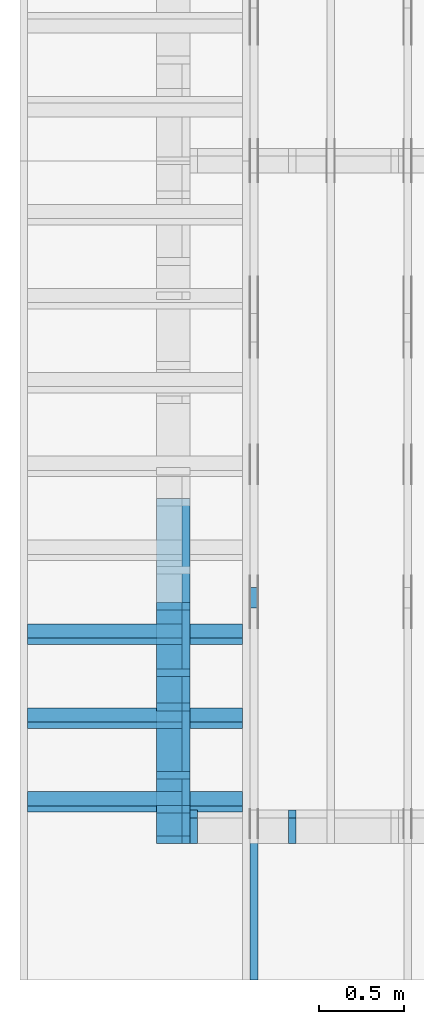
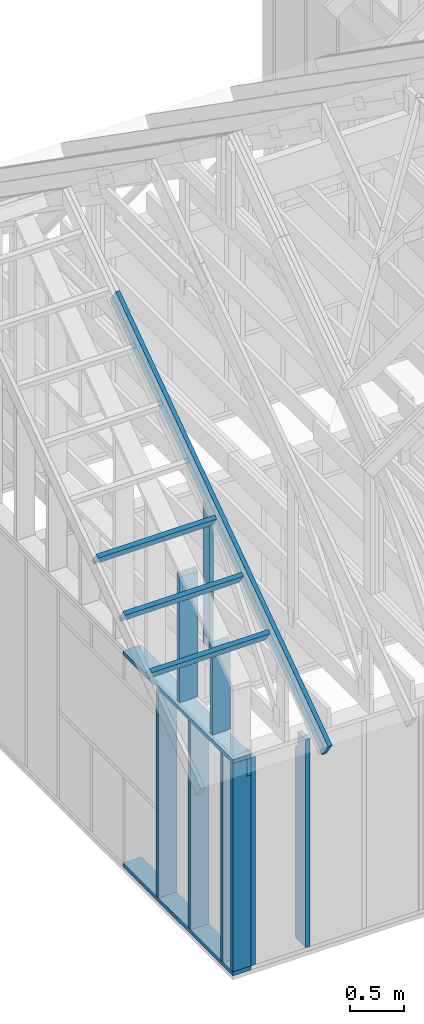
# One storey, part 2 of 70: 16 members, 5 elements without a shape of their own.
"""IFC2X3 building model written with IfcOpenShell, lengths in millimetres."""

from ifc_helpers import new_model, si_unit, frame, origin, origin_with_axes, origin_2d, place, context, project, spatial, faceted_brep, element, aggregate, save


model = new_model("IFC2X3")

# Units and contexts
model_context = context("Model", 3, precision=1e-05, world=origin())
plan_context = context("Plan", 2, precision=1e-05, world=origin_2d())
ifc_project = project(units=[si_unit("LENGTHUNIT", "METRE", prefix="MILLI"), si_unit("AREAUNIT", "SQUARE_METRE"), si_unit("VOLUMEUNIT", "CUBIC_METRE"), si_unit("SOLIDANGLEUNIT", "STERADIAN"), si_unit("PLANEANGLEUNIT", "RADIAN"), si_unit("MASSUNIT", "GRAM"), si_unit("TIMEUNIT", "SECOND"), si_unit("THERMODYNAMICTEMPERATUREUNIT", "DEGREE_CELSIUS"), si_unit("LUMINOUSINTENSITYUNIT", "LUMEN")], contexts=[model_context, plan_context])

# Site, building, storey
site_placement = place(None, origin_with_axes())
site = spatial("IfcSite", under=ifc_project, at=site_placement, CompositionType="ELEMENT")
building_placement = place(site_placement, origin_with_axes())
building = spatial("IfcBuilding", under=site, at=building_placement, Name="Layout 1", CompositionType="ELEMENT")
storey_placement = place(building_placement, origin_with_axes())
storey = spatial("IfcBuildingStorey", under=building, at=storey_placement, Name="Storey 1", CompositionType="ELEMENT", Elevation=0.0)

# Assembly, members
assembly_1_placement = place(storey_placement, frame((304.9999999999989, 8000.000000000001, 1.3776821480501744e-15), z_axis=(-1.0, 1.836909530733566e-16, 6.123031769111886e-17), x_axis=(-1.836909530733566e-16, -1.0, 0.0)))
assembly_1 = element("IfcElementAssembly", 1, at=assembly_1_placement, inside=storey, Name="T2", AssemblyPlace="FACTORY", PredefinedType="TRUSS")
member_1_placement = place(assembly_1_placement, frame((4782.309641268, 3014.9999999994516, -45.00000000000001), z_axis=(0.0, 0.0, 1.0), x_axis=(0.8191520442889916, -0.5735764363510465, 0.0)))
member_1 = element("IfcMember", 2, at=member_1_placement, Name="T9", context=model_context, shape_type="Brep", body=[
    faceted_brep([(4768.153825500908, 195.00000000180353, 45.0), (1.6370904631912708e-10, 195.00000000180353, 45.0), (0.0, 1.8071659724228084e-09, 45.0), (4768.153825500287, 1.8071659724228084e-09, 45.0), (1.6370904631912708e-10, 195.00000000180353, 2.004791383006049e-26), (4768.153825500908, 195.00000000180353, 5.839111470710887e-13), (4768.153825500287, 1.8071659724228084e-09, 5.839111470710126e-13), (0.0, 1.8071659724228084e-09, 0.0), (-1.2523674699591298e-25, 1.8071659724228084e-09, 7.668285805162028e-42), (2.755364295975112e-15, 1.8071659724228084e-09, 45.0), (1.636957134777711e-10, 195.000000001015, 45.0), (1.63692958113475e-10, 195.000000001015, 9.850859431565386e-31), (4768.153825500287, -2.042652045517506e-12, 1.250722336794479e-28), (4768.153825500287, -2.039896681221406e-12, 45.0), (1.0454840658689129e-27, 1.8071687277871045e-09, 45.0), (0.0, 1.8071659724228084e-09, 0.0), (4768.153825500287, 195.00000000180353, -3.8067271842345146e-26), (4768.153825500287, 195.00000000180353, 45.0), (4768.153825500287, 0.0, 45.0), (4768.153825500287, 0.0, 0.0), (1.6370904631912708e-10, 195.000000001015, 0.0), (1.6370904631912708e-10, 195.000000001015, 45.0), (4768.153825500908, 195.00000000180347, 45.0), (4768.153825500908, 195.00000000180347, -4.733165431326071e-30)], [[[0, 1, 2, 3]], [[4, 5, 6, 7]], [[8, 9, 10, 11]], [[12, 13, 14, 15]], [[16, 17, 18, 19]], [[20, 21, 22, 23]]]),
])
member_2_placement = place(assembly_1_placement, frame((6619.999999999389, 220.0, -45.0), z_axis=(0.0, 0.0, 1.0), x_axis=(6.123031769111886e-17, 1.0, 0.0)))
member_2 = element("IfcMember", 3, at=member_2_placement, Name="R1", context=model_context, shape_type="Brep", body=[
    faceted_brep([(1592.2602625068248, 120.0, 45.0), (0.0, 120.0, 45.0), (0.0, 1.4551915228366852e-11, 45.0), (1508.235357921585, 1.4551915228366852e-11, 45.0), (0.0, 120.0, 0.0), (1592.2602625068248, 120.0, 1.949892034404744e-13), (1508.235357921585, 1.4551915228366852e-11, 1.8469946023703405e-13), (0.0, 1.4551915228366852e-11, 0.0), (1.7820367848942657e-27, 1.4551915228366852e-11, -1.0911467847633593e-43), (2.755364296102131e-15, 1.4551915228366852e-11, 45.0), (1.7450640541968876e-14, 120.0, 45.0), (1.4695276245868527e-14, 120.0, -8.997964330932825e-31), (1508.235357921585, -4.605370260698061e-13, 2.81988284147774e-29), (1508.235357921585, -4.577816617737058e-13, 45.0), (2.7425941661909085e-29, 1.4554670592662952e-11, 45.0), (0.0, 1.4551915228366852e-11, 0.0), (1592.260262506825, 120.00000000000011, 1.262177448353619e-29), (1592.260262506825, 120.00000000000011, 45.0), (1508.2353579215853, 0.0, 45.0), (1508.2353579215853, 0.0, 1.262177448353619e-29), (0.0, 120.0, 0.0), (-1.6871183120499046e-31, 120.0, 45.0), (1592.2602625068248, 119.9999999999999, 45.0), (1592.2602625068248, 119.9999999999999, -6.310887241768095e-30)], [[[0, 1, 2, 3]], [[4, 5, 6, 7]], [[8, 9, 10, 11]], [[12, 13, 14, 15]], [[16, 17, 18, 19]], [[20, 21, 22, 23]]]),
])
aggregate(assembly_1, [member_1, member_2])

assembly_2_placement = place(storey_placement, frame((-243.55339059327574, 8000.000000000001, -2470.0), z_axis=(-1.0, 1.836909530733566e-16, 6.123031769111886e-17), x_axis=(-1.836909530733566e-16, -1.0, 0.0)))
assembly_2 = element("IfcElementAssembly", 4, at=assembly_2_placement, inside=storey, Name="VE3", AssemblyPlace="FACTORY", PredefinedType="NOTDEFINED")
member_3_placement = place(assembly_2_placement, frame((5979.999999999998, 2425.0, -195.0), z_axis=(0.0, 0.0, 1.0), x_axis=(1.0, 0.0, 0.0)))
member_3 = element("IfcMember", 5, at=member_3_placement, Name="P11", context=model_context, shape_type="Brep", body=[
    faceted_brep([(2020.0000000000027, 45.0, 195.0), (0.0, 45.0, 195.0), (0.0, 0.0, 195.0), (2020.0000000000027, 0.0, 195.0), (0.0, 45.0, 0.0), (2020.0000000000027, 45.0, 2.4737048347212056e-13), (2020.0000000000027, 0.0, 2.4737048347212056e-13), (0.0, 0.0, 0.0), (0.0, 0.0, 0.0), (1.1939911949768178e-14, -1.462169203776584e-30, 195.0), (1.7450640541968876e-14, 45.0, 195.0), (5.510728592200698e-15, 45.0, -3.3742366240998092e-31), (2020.0000000000027, -3.710557252081808e-13, 2.2719859935605413e-29), (2020.0000000000027, -3.5911581325841264e-13, 195.0), (2.193253805664876e-30, 1.1939911949768178e-14, 195.0), (0.0, 0.0, 0.0), (2020.0000000000027, 45.0, 0.0), (2020.0000000000027, 45.0, 195.0), (2020.0000000000027, 0.0, 195.0), (2020.0000000000027, 0.0, 0.0), (0.0, 45.0, 0.0), (-7.31084601888292e-31, 44.999999999999986, 195.0), (2020.0000000000027, 44.999999999999865, 195.0), (2020.0000000000027, 44.99999999999988, -7.494178599599612e-30)], [[[0, 1, 2, 3]], [[4, 5, 6, 7]], [[8, 9, 10, 11]], [[12, 13, 14, 15]], [[16, 17, 18, 19]], [[20, 21, 22, 23]]]),
])
member_4_placement = place(assembly_2_placement, frame((8000.000000000001, 90.0, -195.0), z_axis=(0.0, 0.0, 1.0), x_axis=(-1.0, 1.2246063538223773e-16, 0.0)))
member_4 = element("IfcMember", 6, at=member_4_placement, Name="P11", context=model_context, shape_type="Brep", body=[
    faceted_brep([(2020.000000000001, 45.00000000000025, 195.0), (0.0, 45.00000000000025, 195.0), (0.0, 0.0, 195.0), (2020.000000000001, 0.0, 195.0), (0.0, 45.00000000000025, 0.0), (2020.000000000001, 45.00000000000025, 2.473704834721203e-13), (2020.000000000001, 0.0, 2.473704834721203e-13), (0.0, 0.0, 0.0), (0.0, 0.0, 0.0), (1.1939911949768178e-14, -1.462169203776584e-30, 195.0), (1.7450640541968876e-14, 45.0, 195.0), (5.510728592200698e-15, 45.0, -3.3742366240998092e-31), (2020.000000000001, -3.7105572520818046e-13, 3.7512157466465997e-29), (2020.000000000001, -3.591158132584123e-13, 195.0), (2.193253805664876e-30, 1.1939911949768178e-14, 195.0), (0.0, 0.0, 0.0), (2020.000000000001, 45.00000000000025, 0.0), (2020.000000000001, 45.00000000000025, 195.0), (2020.000000000001, 2.4158453015843406e-13, 195.0), (2020.000000000001, 2.4158453015843406e-13, 0.0), (0.0, 45.0, 0.0), (1.5777218104420236e-30, 44.999999999999986, 195.0), (2020.000000000001, 45.00000000000031, 195.0), (2020.000000000001, 45.00000000000033, 4.338734978715565e-30)], [[[0, 1, 2, 3]], [[4, 5, 6, 7]], [[8, 9, 10, 11]], [[12, 13, 14, 15]], [[16, 17, 18, 19]], [[20, 21, 22, 23]]]),
])
member_5_placement = place(assembly_2_placement, frame((7955.0, 2425.0, -195.00000000000003), z_axis=(0.0, 0.0, 1.0), x_axis=(-1.836909530733566e-16, -1.0, 0.0)))
member_5 = element("IfcMember", 7, at=member_5_placement, Name="S11", context=model_context, shape_type="Brep", body=[
    faceted_brep([(0.0, 45.0, 45.00000000000003), (195.00000000186265, 45.0, 45.00000000000005), (195.00000000186265, 0.0, 45.00000000000005), (0.0, 0.0, 45.00000000000003), (195.00000000186265, -2.1311460639909362e-46, 2.842170943040401e-14), (195.00000000186265, -3.3742366240998114e-31, 45.00000000000003), (195.00000000186265, 45.0, 45.00000000000003), (195.00000000186265, 45.0, 2.842170943040401e-14), (2.7553642961003504e-15, -3.3742366240998114e-31, 45.00000000000003), (1.193991194976818e-14, -1.4621692037765842e-30, 195.00000000000003), (1.7450640541968876e-14, 45.0, 195.00000000000003), (8.266092888301048e-15, 45.0, 45.00000000000003), (2335.0, -4.2891837542628763e-13, 2.842170943040403e-14), (2335.0, -4.1697846347651946e-13, 195.00000000000003), (2.1932538056648764e-30, 1.193991194976818e-14, 195.00000000000003), (5.061354936149717e-31, 2.7553642961003504e-15, 45.00000000000003), (195.00000000186265, -3.306437155354634e-14, 45.00000000000003), (195.00000000186265, -3.5819735849646686e-14, 2.842170943040401e-14), (-1.6871183120499057e-31, 45.0, 45.00000000000003), (-7.310846018882921e-31, 44.999999999999986, 195.00000000000003), (2335.0, 44.999999999999844, 195.00000000000003), (2335.0, 44.99999999999986, 2.8421709430403998e-14), (195.00000000186265, 44.999999999999986, 2.842170943040401e-14), (195.00000000186265, 44.999999999999986, 45.00000000000003), (2335.0, 45.0, 0.0), (2335.0, 45.0, 195.00000000000003), (2335.0, 0.0, 195.00000000000003), (2335.0, 0.0, 0.0), (2335.0, 45.0, 195.00000000000003), (0.0, 45.0, 195.00000000000003), (0.0, 0.0, 195.00000000000003), (2335.0, 0.0, 195.00000000000003), (195.00000000186265, 45.0, 5.2301533330168465e-14), (2335.0, 45.0, 3.143672930479291e-13), (2335.0, 0.0, 3.143672930479291e-13), (195.00000000186265, 0.0, 5.2301533330168465e-14)], [[[0, 1, 2, 3]], [[4, 5, 6, 7]], [[8, 9, 10, 11]], [[12, 13, 14, 15, 16, 17]], [[18, 19, 20, 21, 22, 23]], [[24, 25, 26, 27]], [[28, 29, 30, 31]], [[32, 33, 34, 35]]]),
])
member_6_placement = place(assembly_2_placement, frame((5980.0, 2230.0, -195.0), z_axis=(0.0, 0.0, 1.0), x_axis=(1.0, 0.0, 0.0)))
member_6 = element("IfcMember", 8, at=member_6_placement, Name="L8", context=model_context, shape_type="Brep", body=[
    faceted_brep([(2020.000000000001, 195.0, 45.0), (0.0, 195.0, 45.0), (0.0, 0.0, 45.0), (2020.000000000001, 0.0, 45.0), (0.0, 195.0, 0.0), (2020.000000000001, 195.0, 2.473704834721203e-13), (2020.000000000001, 0.0, 2.473704834721203e-13), (0.0, 0.0, 0.0), (0.0, 0.0, 0.0), (2.755364296100349e-15, -3.3742366240998092e-31, 45.0), (2.6635188195636705e-14, 195.0, 45.0), (2.3879823899536357e-14, 195.0, -1.462169203776584e-30), (2020.000000000001, -3.7105572520818046e-13, 2.2719859935605393e-29), (2020.000000000001, -3.683003609120801e-13, 45.0), (5.061354936149714e-31, 2.755364296100349e-15, 45.0), (0.0, 0.0, 0.0), (2020.000000000001, 195.0, 0.0), (2020.000000000001, 195.0, 45.0), (2020.000000000001, 0.0, 45.0), (2020.000000000001, 0.0, 0.0), (0.0, 195.0, 0.0), (-1.6871183120499046e-31, 195.0, 45.0), (2020.000000000001, 194.9999999999999, 45.0), (2020.000000000001, 194.9999999999999, -7.888609052210118e-30)], [[[0, 1, 2, 3]], [[4, 5, 6, 7]], [[8, 9, 10, 11]], [[12, 13, 14, 15]], [[16, 17, 18, 19]], [[20, 21, 22, 23]]]),
])
member_7_placement = place(assembly_2_placement, frame((7177.5000000018335, 2425.0, -195.0), z_axis=(0.0, 0.0, 1.0), x_axis=(-1.836909530733566e-16, -1.0, 0.0)))
member_7 = element("IfcMember", 9, at=member_7_placement, Name="S11", context=model_context, shape_type="Brep", body=[
    faceted_brep([(0.0, 44.99999999998545, 45.0), (195.00000000186265, 44.99999999998545, 45.00000000000002), (195.00000000186265, 0.0, 45.00000000000002), (0.0, 0.0, 45.0), (195.00000000186265, 0.0, 0.0), (195.00000000186265, -3.3742366240998092e-31, 45.0), (195.00000000186265, 44.99999999998545, 45.0), (195.00000000186265, 44.99999999998545, 0.0), (2.755364296100349e-15, -3.3742366240998092e-31, 45.0), (1.1939911949768178e-14, -1.462169203776584e-30, 195.0), (1.7450640541967096e-14, 44.99999999998545, 195.00000000000003), (8.266092888299264e-15, 44.99999999998545, 45.0), (2335.0, -4.2891837542628763e-13, 2.626280839091018e-29), (2335.0, -4.1697846347651946e-13, 195.0), (2.193253805664876e-30, 1.1939911949768178e-14, 195.0), (5.061354936149714e-31, 2.755364296100349e-15, 45.0), (195.00000000186265, -3.306437155354634e-14, 45.0), (195.00000000186265, -3.5819735849646686e-14, 2.193253805685826e-30), (-1.6871183120499046e-31, 44.99999999998545, 45.0), (-7.31084601888292e-31, 44.999999999985434, 195.0), (2335.0, 44.99999999998529, 195.0), (2335.0, 44.999999999985306, -8.67746995743113e-30), (195.00000000186265, 44.999999999985434, -7.888609052210118e-31), (195.00000000186265, 44.999999999985434, 45.0), (2335.0, 44.99999999998545, 2.842170943040401e-14), (2335.0, 44.99999999998545, 195.0), (2335.0, 0.0, 195.0), (2335.0, 0.0, 0.0), (2335.0, 44.99999999998545, 195.0), (0.0, 44.99999999998545, 195.0), (0.0, 0.0, 195.0), (2335.0, 0.0, 195.0), (195.00000000186265, 44.99999999998545, 2.3879823899764457e-14), (2335.0, 44.99999999998545, 2.859455836175251e-13), (2335.0, 0.0, 2.859455836175251e-13), (195.00000000186265, 0.0, 2.3879823899764457e-14)], [[[0, 1, 2, 3]], [[4, 5, 6, 7]], [[8, 9, 10, 11]], [[12, 13, 14, 15, 16, 17]], [[18, 19, 20, 21, 22, 23]], [[24, 25, 26, 27]], [[28, 29, 30, 31]], [[32, 33, 34, 35]]]),
])
member_8_placement = place(assembly_2_placement, frame((7777.500000001819, 2425.0, -195.00000000000003), z_axis=(0.0, 0.0, 1.0), x_axis=(-1.836909530733566e-16, -1.0, 0.0)))
member_8 = element("IfcMember", 10, at=member_8_placement, Name="S11", context=model_context, shape_type="Brep", body=[
    faceted_brep([(0.0, 45.0, 45.00000000000003), (195.00000000186265, 45.0, 45.00000000000005), (195.00000000186265, 0.0, 45.00000000000005), (0.0, 0.0, 45.00000000000003), (195.00000000186265, -2.1311460639909362e-46, 2.842170943040401e-14), (195.00000000186265, -3.3742366240998114e-31, 45.00000000000003), (195.00000000186265, 45.0, 45.00000000000003), (195.00000000186265, 45.0, 2.842170943040401e-14), (2.7553642961003504e-15, -3.3742366240998114e-31, 45.00000000000003), (1.193991194976818e-14, -1.4621692037765842e-30, 195.00000000000003), (1.7450640541968876e-14, 45.0, 195.00000000000003), (8.266092888301048e-15, 45.0, 45.00000000000003), (2335.0, -4.2891837542628763e-13, 2.842170943040403e-14), (2335.0, -4.1697846347651946e-13, 195.00000000000003), (2.1932538056648764e-30, 1.193991194976818e-14, 195.00000000000003), (5.061354936149717e-31, 2.7553642961003504e-15, 45.00000000000003), (195.00000000186265, -3.306437155354634e-14, 45.00000000000003), (195.00000000186265, -3.5819735849646686e-14, 2.842170943040401e-14), (-1.6871183120499057e-31, 45.0, 45.00000000000003), (-7.310846018882921e-31, 44.999999999999986, 195.00000000000003), (2335.0, 44.999999999999844, 195.00000000000003), (2335.0, 44.99999999999986, 2.8421709430403998e-14), (195.00000000186265, 44.999999999999986, 2.842170943040401e-14), (195.00000000186265, 44.999999999999986, 45.00000000000003), (2335.0, 45.0, 0.0), (2335.0, 45.0, 195.00000000000003), (2335.0, 0.0, 195.00000000000003), (2335.0, 0.0, 0.0), (2335.0, 45.0, 195.00000000000003), (0.0, 45.0, 195.00000000000003), (0.0, 0.0, 195.00000000000003), (2335.0, 0.0, 195.00000000000003), (195.00000000186265, 45.0, 5.2301533330168465e-14), (2335.0, 45.0, 3.143672930479291e-13), (2335.0, 0.0, 3.143672930479291e-13), (195.00000000186265, 0.0, 5.2301533330168465e-14)], [[[0, 1, 2, 3]], [[4, 5, 6, 7]], [[8, 9, 10, 11]], [[12, 13, 14, 15, 16, 17]], [[18, 19, 20, 21, 22, 23]], [[24, 25, 26, 27]], [[28, 29, 30, 31]], [[32, 33, 34, 35]]]),
])
member_9_placement = place(assembly_2_placement, frame((6587.5000000036525, 2425.0, -195.00000000000003), z_axis=(0.0, 0.0, 1.0), x_axis=(-1.836909530733566e-16, -1.0, 0.0)))
member_9 = element("IfcMember", 11, at=member_9_placement, Name="S11", context=model_context, shape_type="Brep", body=[
    faceted_brep([(0.0, 45.000000000029104, 45.00000000000003), (195.00000000186265, 45.000000000029104, 45.00000000000005), (195.00000000186265, 0.0, 45.00000000000005), (0.0, 0.0, 45.00000000000003), (195.00000000186265, 9.094947017729282e-13, 2.842170943040401e-14), (195.00000000186265, 9.094947017729282e-13, 45.00000000000003), (195.00000000186265, 45.000000000028194, 45.00000000000003), (195.00000000186265, 45.000000000028194, 2.842170943040401e-14), (2.7553642961003504e-15, -3.3742366240998114e-31, 45.00000000000003), (1.1939911949768181e-14, -1.4621692037765844e-30, 195.00000000000006), (1.7450640541972442e-14, 45.000000000029104, 195.00000000000006), (8.266092888304612e-15, 45.000000000029104, 45.00000000000003), (2335.0, -4.2891837542628763e-13, 2.842170943040403e-14), (2335.0, -4.1697846347651946e-13, 195.00000000000003), (2.1932538056648764e-30, 1.193991194976818e-14, 195.00000000000003), (5.061354936149717e-31, 2.7553642961003504e-15, 45.00000000000003), (195.00000000186265, -3.306437155354634e-14, 45.00000000000003), (195.00000000186265, -3.5819735849646686e-14, 2.842170943040401e-14), (-1.6871183120499057e-31, 45.000000000028194, 45.00000000000003), (-7.310846018882921e-31, 45.00000000002818, 195.00000000000003), (2335.0, 45.00000000002804, 195.00000000000003), (2335.0, 45.00000000002805, 2.8421709430403998e-14), (195.00000000186265, 45.00000000002818, 2.842170943040401e-14), (195.00000000186265, 45.00000000002818, 45.00000000000003), (2335.0, 45.00000000001455, 0.0), (2335.0, 45.00000000001455, 195.00000000000003), (2335.0, 1.4551915228366852e-11, 195.00000000000003), (2335.0, 1.4551915228366852e-11, 0.0), (2335.0, 45.00000000001455, 195.00000000000003), (0.0, 45.00000000001455, 195.00000000000003), (0.0, 0.0, 195.00000000000003), (2335.0, 0.0, 195.00000000000003), (195.00000000186265, 45.000000000028194, 5.2301533330168465e-14), (2335.0, 45.000000000028194, 3.143672930479291e-13), (2335.0, 1.4551915228366852e-11, 3.143672930479291e-13), (195.00000000186265, 1.4551915228366852e-11, 5.2301533330168465e-14)], [[[0, 1, 2, 3]], [[4, 5, 6, 7]], [[8, 9, 10, 11]], [[12, 13, 14, 15, 16, 17]], [[18, 19, 20, 21, 22, 23]], [[24, 25, 26, 27]], [[28, 29, 30, 31]], [[32, 33, 34, 35]]]),
])
aggregate(assembly_2, [member_3, member_4, member_5, member_6, member_7, member_8, member_9])

assembly_3_placement = place(storey_placement, frame((-48.55339059325575, 0.0, -2470.0), z_axis=(0.0, -1.0, 6.123031769111886e-17), x_axis=(1.0, 0.0, 0.0)))
assembly_3 = element("IfcElementAssembly", 12, at=assembly_3_placement, inside=storey, Name="VE4", AssemblyPlace="FACTORY", PredefinedType="NOTDEFINED")
member_10_placement = place(assembly_3_placement, frame((45.00000000000001, 90.0000000000013, -195.00000000000003), z_axis=(0.0, 0.0, 1.0), x_axis=(6.123031769111886e-17, 1.0, 0.0)))
member_10 = element("IfcMember", 13, at=member_10_placement, Name="S11", context=model_context, shape_type="Brep", body=[
    faceted_brep([(2139.999999998136, 45.000000000000135, 2.842170943040401e-14), (2139.999999998136, 45.000000000000135, 45.00000000000003), (2139.999999998136, 1.3500311979441904e-13, 45.00000000000003), (2139.999999998136, 1.3500311979441904e-13, 2.842170943040401e-14), (2139.999999998136, 45.000000000000135, 45.00000000000029), (2334.9999999999986, 45.000000000000135, 45.00000000000031), (2334.9999999999986, 1.3500311979441904e-13, 45.00000000000031), (2139.999999998136, 1.3500311979441904e-13, 45.00000000000029), (7.105427357601002e-14, 45.00000000000015, 2.842170943040401e-14), (7.105427357601002e-14, 45.000000000000135, 195.00000000000003), (2334.9999999999986, 44.99999999999999, 195.00000000000003), (2334.9999999999986, 45.0, 45.00000000000003), (2139.999999998136, 45.000000000000014, 45.00000000000003), (2139.999999998136, 45.00000000000002, 2.8421709430404e-14), (7.105427357601002e-14, 45.00000000000001, 2.8421709430404014e-14), (2139.999999998136, 45.00000000000001, 2.904874691481645e-13), (2139.999999998136, 1.3500311979441904e-13, 2.904874691481645e-13), (7.105427357601002e-14, 1.3500311979441904e-13, 2.8421709430404014e-14), (7.105427357601002e-14, 0.0, 0.0), (1.695915814465404e-13, 2.067298346342007e-28, 195.00000000000003), (7.5182237822477e-14, 45.000000000000014, 195.00000000000003), (-2.3355070048053398e-14, 45.000000000000014, 1.1801772962373546e-29), (2334.9999999999986, -2.91159891335768e-13, 45.00000000000003), (2334.9999999999986, -2.8197534368210017e-13, 195.00000000000003), (7.105427357601002e-14, 1.4694303174418721e-13, 195.00000000000003), (7.105427357601002e-14, 1.3500311979441904e-13, 2.8421709430404004e-14), (2139.999999998136, -2.5809551978222166e-13, 2.842170943040403e-14), (2139.999999998136, -2.553401554861213e-13, 45.00000000000003), (2334.9999999999986, 45.000000000000156, 45.00000000000003), (2334.9999999999986, 45.000000000000156, 195.00000000000003), (2334.9999999999986, 1.5631940186722204e-13, 195.00000000000003), (2334.9999999999986, 1.5631940186722204e-13, 45.00000000000003), (2334.9999999999986, 45.00000000000015, 195.00000000000003), (7.105427357601002e-14, 45.00000000000015, 195.00000000000003), (7.105427357601002e-14, 7.105427357601002e-15, 195.00000000000003), (2334.9999999999986, 7.105427357601002e-15, 195.00000000000003)], [[[0, 1, 2, 3]], [[4, 5, 6, 7]], [[8, 9, 10, 11, 12, 13]], [[14, 15, 16, 17]], [[18, 19, 20, 21]], [[22, 23, 24, 25, 26, 27]], [[28, 29, 30, 31]], [[32, 33, 34, 35]]]),
])
member_11_placement = place(assembly_3_placement, frame((577.500000001819, 2425.0, -195.00000000000003), z_axis=(0.0, 0.0, 1.0), x_axis=(-1.836909530733566e-16, -1.0, 0.0)))
member_11 = element("IfcMember", 14, at=member_11_placement, Name="S11", context=model_context, shape_type="Brep", body=[
    faceted_brep([(0.0, 45.00000000001455, 45.00000000000003), (195.00000000186265, 45.00000000001455, 45.00000000000005), (195.00000000186265, 0.0, 45.00000000000005), (0.0, 0.0, 45.00000000000003), (195.00000000186265, 1.2505552149377763e-12, 2.842170943040401e-14), (195.00000000186265, 1.2505552149377763e-12, 45.00000000000003), (195.00000000186265, 45.00000000001455, 45.00000000000003), (195.00000000186265, 45.00000000001455, 2.842170943040401e-14), (2.7553642961003504e-15, -3.3742366240998114e-31, 45.00000000000003), (1.1939911949768181e-14, -1.4621692037765844e-30, 195.00000000000006), (1.7450640541970662e-14, 45.00000000001455, 195.00000000000006), (8.26609288830283e-15, 45.00000000001455, 45.00000000000003), (2335.0, -4.2891837542628763e-13, 2.842170943040403e-14), (2335.0, -4.1697846347651946e-13, 195.00000000000003), (2.1932538056648764e-30, 1.193991194976818e-14, 195.00000000000003), (5.061354936149717e-31, 2.7553642961003504e-15, 45.00000000000003), (195.00000000186265, -3.306437155354634e-14, 45.00000000000003), (195.00000000186265, -3.5819735849646686e-14, 2.842170943040401e-14), (-1.6871183120499057e-31, 45.00000000001455, 45.00000000000003), (-7.310846018882921e-31, 45.00000000001454, 195.00000000000003), (2335.0, 45.000000000014396, 195.00000000000003), (2335.0, 45.00000000001441, 2.8421709430403992e-14), (195.00000000186265, 45.00000000001454, 2.8421709430404004e-14), (195.00000000186265, 45.00000000001454, 45.00000000000003), (2335.0, 45.00000000001501, 0.0), (2335.0, 45.00000000001501, 195.00000000000003), (2335.0, 1.5006662579253316e-11, 195.00000000000003), (2335.0, 1.5006662579253316e-11, 0.0), (2335.0, 45.00000000001501, 195.00000000000003), (0.0, 45.00000000001501, 195.00000000000003), (0.0, 0.0, 195.00000000000003), (2335.0, 0.0, 195.00000000000003), (195.00000000186265, 45.00000000001455, 5.2301533330168465e-14), (2335.0, 45.00000000001455, 3.143672930479291e-13), (2335.0, 1.5006662579253316e-11, 3.143672930479291e-13), (195.00000000186265, 1.5006662579253316e-11, 5.2301533330168465e-14)], [[[0, 1, 2, 3]], [[4, 5, 6, 7]], [[8, 9, 10, 11]], [[12, 13, 14, 15, 16, 17]], [[18, 19, 20, 21, 22, 23]], [[24, 25, 26, 27]], [[28, 29, 30, 31]], [[32, 33, 34, 35]]]),
])
aggregate(assembly_3, [member_10, member_11])

assembly_4_placement = place(storey_placement, frame((-48.55339059327645, 2.2546681725408788e-11, 1.1939911949768178e-14), z_axis=(1.0, 1.156240088482502e-13, 6.123031769111886e-17), x_axis=(-1.156240088482502e-13, 1.0, 0.0)))
assembly_4 = element("IfcElementAssembly", 15, at=assembly_4_placement, inside=storey, Name="VEg1", AssemblyPlace="FACTORY", PredefinedType="NOTDEFINED")
member_12_placement = place(assembly_4_placement, frame((422.49999999842765, 44.99999999999997, -195.0), z_axis=(0.0, 0.0, 1.0), x_axis=(7.273641324662128e-16, 1.0, 0.0)))
member_12 = element("IfcMember", 16, at=member_12_placement, Name="S30", context=model_context, shape_type="Brep", body=[
    faceted_brep([(987.381173808084, 44.99999999999994, 195.0), (0.0, 44.99999999999994, 195.0), (2.842170943040401e-14, 2.83648660115432e-11, 195.0), (1018.8905130275307, 2.83648660115432e-11, 195.0), (0.0, 44.99999999999994, 0.0), (987.381173808084, 44.99999999999994, 1.2091532590899766e-13), (1018.8905130275307, 2.83648660115432e-11, 1.2477397961028557e-13), (2.842170943040401e-14, 2.83648660115432e-11, 3.4805405954966126e-30), (2.84217094304128e-14, 2.83648660115432e-11, -5.3809861030072976e-43), (4.036162138018098e-14, 2.83648660115432e-11, 195.0), (2.588833552913354e-14, 45.00000000001381, 195.0), (1.3948423579365361e-14, 45.00000000001381, -8.540664070548342e-31), (1018.8905130275307, 1.24051505172268e-13, -7.595713071759457e-30), (1018.8905130275307, 1.3599141712203618e-13, 195.0), (2.842170943040434e-14, 2.8376805923492968e-11, 195.0), (2.842170943040401e-14, 2.83648660115432e-11, 0.0), (987.381173808084, 44.99999999999983, 0.0), (987.381173808084, 44.99999999999983, 195.0), (1018.8905130275307, -5.684341886080802e-14, 195.0), (1018.8905130275307, -5.684341886080802e-14, 0.0), (0.0, 45.00000000001381, 0.0), (-2.0194839173657902e-28, 45.0000000000138, 195.0), (987.3811738080841, 45.00000000000015, 195.0), (987.3811738080841, 45.000000000000156, 1.3016204936146695e-29)], [[[0, 1, 2, 3]], [[4, 5, 6, 7]], [[8, 9, 10, 11]], [[12, 13, 14, 15]], [[16, 17, 18, 19]], [[20, 21, 22, 23]]]),
])
member_13_placement = place(assembly_4_placement, frame((1022.499999994965, 44.99999999999998, -195.0), z_axis=(0.0, 0.0, 1.0), x_axis=(5.053195275411815e-16, 1.0, 0.0)))
member_13 = element("IfcMember", 17, at=member_13_placement, Name="S20", context=model_context, shape_type="Brep", body=[
    faceted_brep([(1407.5056967315759, 45.00000000000068, 195.0), (0.0, 45.00000000000068, 195.0), (2.1316282072803006e-14, 0.0, 195.0), (1439.0150359510226, 0.0, 195.0), (0.0, 45.00000000000068, 0.0), (1407.5056967315759, 45.00000000000068, 1.7236404192586798e-13), (1439.0150359510226, 0.0, 1.7622269562715589e-13), (2.1316282072803006e-14, 0.0, 2.6104054466224595e-30), (2.131628207280301e-14, 1.401298464324817e-45, -1.7516230804060213e-46), (3.3256194022571184e-14, 3.840216859675288e-30, 195.0), (1.8782908171514387e-14, 45.00000000001455, 195.0), (6.842996221746209e-15, 45.00000000001455, -4.189988326166464e-31), (1439.0150359510226, -2.643340434407338e-13, 6.491282579340672e-29), (1439.0150359510226, -2.5239413149096564e-13, 195.0), (2.131628207280301e-14, 1.1939911949768164e-14, 195.0), (2.1316282072803006e-14, -1.5703994310500744e-29, 9.615605606514836e-46), (1407.5056967315759, 45.00000000000068, -1.262177448353619e-29), (1407.5056967315759, 45.00000000000068, 195.0), (1439.0150359510226, 9.094947017729282e-13, 195.0), (1439.0150359510226, 9.094947017729282e-13, 0.0), (0.0, 45.00000000001455, 0.0), (-1.0097419586828951e-28, 45.00000000001454, 195.0), (1407.5056967315759, 45.000000000001016, 195.0), (1407.5056967315759, 45.00000000000103, 2.0904813988356813e-29)], [[[0, 1, 2, 3]], [[4, 5, 6, 7]], [[8, 9, 10, 11]], [[12, 13, 14, 15]], [[16, 17, 18, 19]], [[20, 21, 22, 23]]]),
])
aggregate(assembly_4, [member_12, member_13])

assembly_5_placement = place(storey_placement, frame((304.99999999999886, -800.0, 439.83396943223215), z_axis=(-2.4046889635939937e-17, -0.573576436351046, 0.8191520442889918), x_axis=(1.5036672491230068e-17, 0.8191520442889918, 0.573576436351046)))
assembly_5 = element("IfcElementAssembly", 18, at=assembly_5_placement, inside=storey, Name="gs1", AssemblyPlace="FACTORY", PredefinedType="TRUSS")
member_14_placement = place(assembly_5_placement, frame((1244.999999998996, 44.99999999999999, -145.0), z_axis=(0.0, 0.0, 1.0), x_axis=(6.123031769111886e-17, 1.0, 0.0)))
member_14 = element("IfcMember", 19, at=member_14_placement, Name="W4", context=model_context, shape_type="Brep", body=[
    faceted_brep([(1258.5533905932764, 45.00000000001455, 145.0), (0.0, 45.00000000001455, 145.0), (7.105427357601002e-15, 0.0, 145.0), (1258.5533905932764, 0.0, 145.0), (0.0, 45.00000000001455, 0.0), (1258.5533905932764, 45.00000000001455, 1.5412324787452224e-13), (1258.5533905932764, 0.0, 1.5412324787452224e-13), (7.105427357601002e-15, 0.0, 8.701351488741532e-31), (7.105427357601002e-15, 0.0, 0.0), (1.5983823422813237e-14, -1.0872540233210496e-30, 145.0), (2.1494552015015717e-14, 45.00000000001455, 145.0), (1.2616155949803482e-14, 45.00000000001455, -7.724912368471666e-31), (1258.5533905932764, 1.5418294590103406e-11, -5.3048683560158e-29), (1258.5533905932764, 1.5427172986168618e-11, 145.0), (7.105427357600893e-15, 8.87839606521224e-15, 145.0), (7.105427357601002e-15, 4.891326553927039e-30, -2.994974788279585e-46), (1258.5533905932764, 45.00000000001455, 0.0), (1258.5533905932764, 45.00000000001455, 145.0), (1258.5533905932764, 1.4551915228366852e-11, 145.0), (1258.5533905932764, 1.4551915228366852e-11, 0.0), (-1.2154326714572542e-63, 45.00000000001455, 0.0), (-5.436270116605248e-31, 45.000000000014545, 145.0), (1258.5533905932764, 45.00000000001447, 145.0), (1258.5533905932764, 45.000000000014474, -4.733165431326071e-30)], [[[0, 1, 2, 3]], [[4, 5, 6, 7]], [[8, 9, 10, 11]], [[12, 13, 14, 15]], [[16, 17, 18, 19]], [[20, 21, 22, 23]]]),
])
member_15_placement = place(assembly_5_placement, frame((1844.9999999989814, 45.0, -145.0), z_axis=(0.0, 0.0, 1.0), x_axis=(6.123031769111886e-17, 1.0, 0.0)))
member_15 = element("IfcMember", 20, at=member_15_placement, Name="W4", context=model_context, shape_type="Brep", body=[
    faceted_brep([(1258.5533905932762, 45.0, 145.0), (0.0, 45.0, 145.0), (0.0, 0.0, 145.0), (1258.5533905932762, 0.0, 145.0), (0.0, 45.0, 0.0), (1258.5533905932762, 45.0, 1.5412324787452222e-13), (1258.5533905932762, 0.0, 1.5412324787452222e-13), (0.0, 0.0, 0.0), (0.0, 0.0, 0.0), (8.878396065212235e-15, -1.0872540233210496e-30, 145.0), (1.4389124657414716e-14, 45.00000000001455, 145.0), (5.51072859220248e-15, 45.00000000001455, -3.3742366241009005e-31), (1258.5533905932762, -2.311848718117833e-13, 1.4155523146416083e-29), (1258.5533905932762, -2.2230647574657107e-13, 145.0), (1.6308810349815745e-30, 8.878396065212235e-15, 145.0), (0.0, 0.0, 0.0), (1258.5533905932762, 45.0, 0.0), (1258.5533905932762, 45.0, 145.0), (1258.5533905932762, 0.0, 145.0), (1258.5533905932762, 0.0, 0.0), (0.0, 45.00000000001455, 0.0), (-1.0097419586828951e-28, 45.000000000014545, 145.0), (1258.5533905932762, 44.999999999999936, 145.0), (1258.5533905932762, 44.99999999999994, -3.549874073494553e-30)], [[[0, 1, 2, 3]], [[4, 5, 6, 7]], [[8, 9, 10, 11]], [[12, 13, 14, 15]], [[16, 17, 18, 19]], [[20, 21, 22, 23]]]),
])
member_16_placement = place(assembly_5_placement, frame((2444.9999999989814, 45.0, -145.0), z_axis=(0.0, 0.0, 1.0), x_axis=(6.123031769111886e-17, 1.0, 0.0)))
member_16 = element("IfcMember", 21, at=member_16_placement, Name="W4", context=model_context, shape_type="Brep", body=[
    faceted_brep([(1258.5533905932764, 45.0, 145.0), (0.0, 45.0, 145.0), (0.0, 1.4551915228366852e-11, 145.0), (1258.5533905932764, 1.4551915228366852e-11, 145.0), (0.0, 45.0, 0.0), (1258.5533905932764, 45.0, 1.5412324787452224e-13), (1258.5533905932764, 1.4551915228366852e-11, 1.5412324787452224e-13), (0.0, 1.4551915228366852e-11, 0.0), (1.7820367848942657e-27, 1.4551915228366852e-11, -1.0911467847633593e-43), (8.878396065214018e-15, 1.4551915228366852e-11, 145.0), (1.4389124657412933e-14, 45.0, 145.0), (5.510728592200698e-15, 45.0, -3.3742366240998092e-31), (1258.5533905932764, -2.1092914379474964e-13, 1.2915258484868272e-29), (1258.5533905932764, -2.020507477295374e-13, 145.0), (1.0414367826171774e-28, 1.4560793624432064e-11, 145.0), (0.0, 1.4551915228366852e-11, 0.0), (1258.5533905932764, 45.0, 0.0), (1258.5533905932764, 45.0, 145.0), (1258.5533905932764, 0.0, 145.0), (1258.5533905932764, 0.0, 0.0), (0.0, 45.0, 0.0), (-5.436270116605248e-31, 44.99999999999999, 145.0), (1258.5533905932764, 44.999999999999915, 145.0), (1258.5533905932764, 44.99999999999992, -4.733165431326071e-30)], [[[0, 1, 2, 3]], [[4, 5, 6, 7]], [[8, 9, 10, 11]], [[12, 13, 14, 15]], [[16, 17, 18, 19]], [[20, 21, 22, 23]]]),
])
aggregate(assembly_5, [member_14, member_15, member_16])

save(model, "model.ifc")
